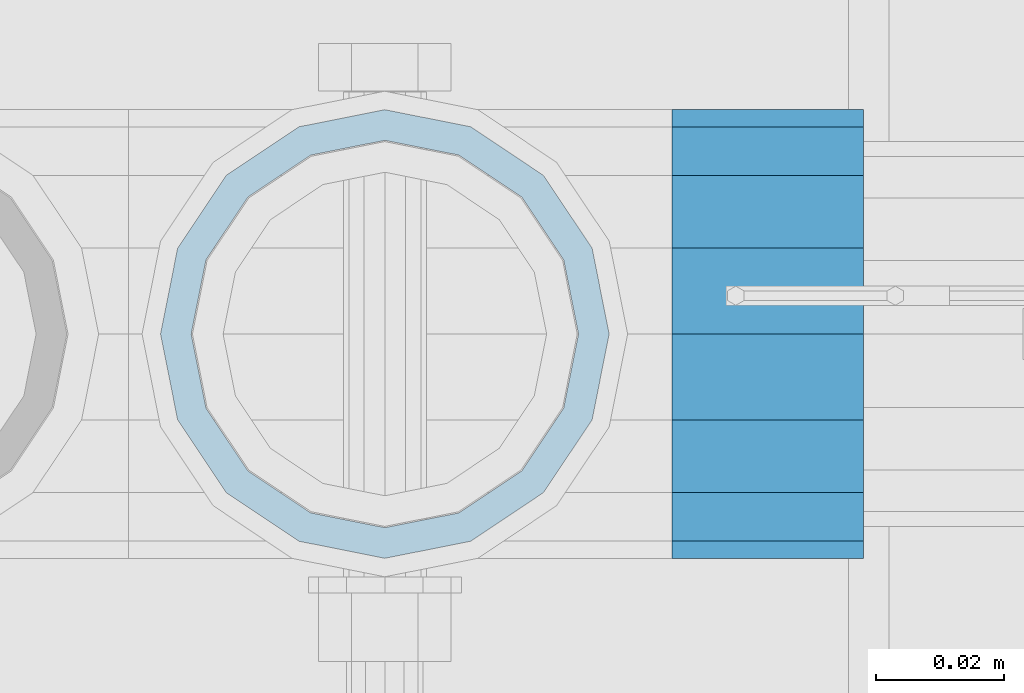
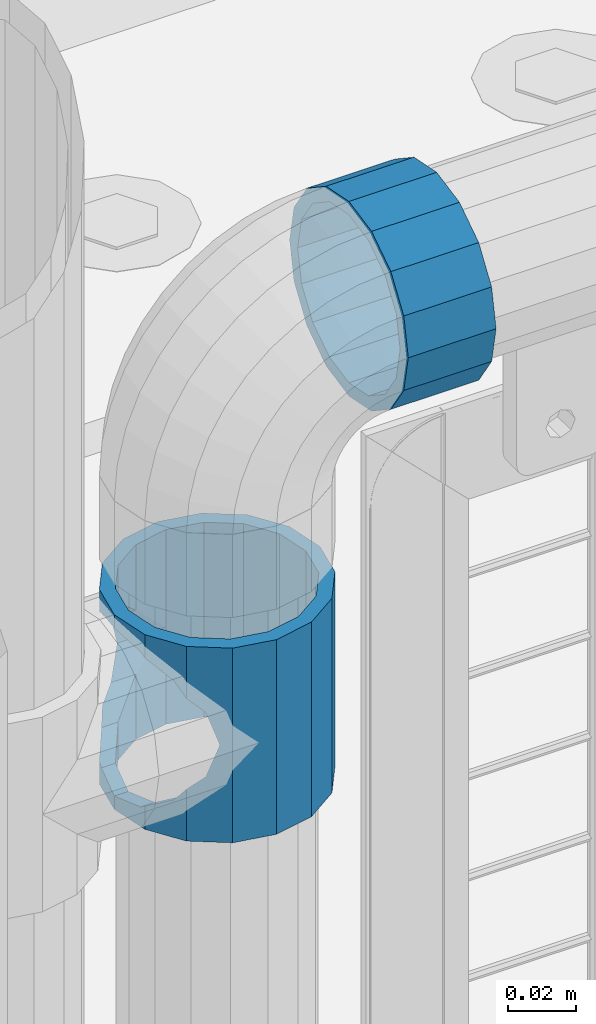
# One storey, part 146 of 240: 2 beams.
"""IFC2X3 building model written with IfcOpenShell, lengths in millimetres."""

from ifc_helpers import new_model, si_unit, frame, origin_with_axes, place, context, subcontext, project, spatial, faceted_brep, material, type_object, element, save


model = new_model("IFC2X3")

# Units and contexts
model_context = context("Model", 3, precision=1e-05, world=origin_with_axes())
body_context = subcontext(model_context, "Body", "Model", "MODEL_VIEW")
ifc_project = project(units=[si_unit("LENGTHUNIT", "METRE", prefix="MILLI"), si_unit("AREAUNIT", "SQUARE_METRE"), si_unit("VOLUMEUNIT", "CUBIC_METRE"), si_unit("MASSUNIT", "GRAM", prefix="KILO"), si_unit("TIMEUNIT", "SECOND"), si_unit("PLANEANGLEUNIT", "RADIAN"), si_unit("SOLIDANGLEUNIT", "STERADIAN"), si_unit("THERMODYNAMICTEMPERATUREUNIT", "DEGREE_CELSIUS"), si_unit("LUMINOUSINTENSITYUNIT", "LUMEN")], contexts=[model_context])

# Site, building, storey
site_placement = place(None, origin_with_axes())
site = spatial("IfcSite", under=ifc_project, at=site_placement, CompositionType="ELEMENT")
building_placement = place(site_placement, origin_with_axes())
building = spatial("IfcBuilding", under=site, at=building_placement, Name="Standard", CompositionType="ELEMENT")
storey_placement = place(building_placement, origin_with_axes())
storey = spatial("IfcBuildingStorey", under=building, at=storey_placement, Name="Undefined", CompositionType="ELEMENT", Elevation=0.0)

# Beams
ifc_material = material(Name="Misc_Undefined")
beam_type = type_object("IfcBeamType", PredefinedType="NOTDEFINED")
beam_1_placement = place(storey_placement, frame((43071.0, 34664.5, 883.820000000001), z_axis=(1.0, 0.0, 0.0), x_axis=(0.0, 0.0, -1.0)))
element("IfcBeam", 1, at=beam_1_placement, inside=storey, type_object=beam_type, material=ifc_material, context=body_context, shape_type="Brep", body=[
    faceted_brep([(46.7644421722801, 28.0397438117143, -11.6144421722784), (46.7644421722801, 28.0397438117143, -20.0882031229849), (51.5310424079941, 24.8548033587067, -24.8548033587067), (56.6106908090114, 21.4606908090136, -27.1226768591077), (56.6106908090114, 21.4606908090136, -21.4606908090136), (61.9623795176703, 13.4513226476338, -32.4743655677739), (63.1897438117172, 11.6144421722784, -32.8397438117172), (63.1897438117172, 11.6144421722784, -28.0397438117143), (65.4999999999997, 0.0, -35.1500000000015), (65.4999999999997, 0.0, -30.3499999999985), (63.1897438117172, -11.6144421722784, -32.8397438117245), (63.1897438117172, -11.6144421722784, -28.0397438117143), (61.9623795176703, -13.4513226476338, -32.4743655677739), (56.6106908090114, -21.4606908090136, -27.1226768591223), (56.6106908090114, -21.4606908090136, -21.4606908090136), (51.5310424080006, -24.8548033587067, -24.8548033587067), (46.7644421722801, -28.0397438117143, -20.0882031229994), (46.7644421722801, -28.0397438117143, -11.6144421722784), (35.1499999999996, -30.3499999999985, -16.6306603983758), (35.1500000000015, -30.35, 0.0), (23.5355578277191, -28.0397438117143, -20.0882031229994), (23.5355578277191, -28.0397438117143, -11.6144421722784), (18.7689575919987, -24.8548033587067, -24.8548033587067), (13.6893091909879, -21.4606908090136, -27.1226768591223), (13.6893091909879, -21.4606908090136, -21.4606908090136), (8.33762048232455, -13.4513226476338, -32.4743655677739), (7.11025618828211, -11.6144421722784, -32.8397438117245), (7.11025618828211, -11.6144421722784, -28.0397438117143), (4.79999999999961, 0.0, -35.1500000000015), (4.79999999999961, 0.0, -30.3499999999985), (7.11025618828211, 11.6144421722784, -32.8397438117172), (7.11025618828211, 11.6144421722784, -28.0397438117143), (8.33762048232893, 13.4513226476338, -32.4743655677739), (13.6893091909879, 21.4606908090136, -27.1226768591077), (13.6893091909879, 21.4606908090136, -21.4606908090136), (18.7689575919921, 24.8548033587067, -24.8548033587067), (23.5355578277192, 28.0397438117143, -20.0882031229849), (23.5355578277192, 28.0397438117143, -11.6144421722784), (35.1499999999996, 30.3499999999985, -16.6306603983685), (35.1500000000015, 30.35, 0.0), (0.0, 32.4743655677739, -13.4513226476338), (0.0, 35.1500000000015, 0.0), (70.2999999999993, 35.1500000000015, 0.0), (70.2999999999993, 32.4743655677739, -13.4513226476338), (0.0, 32.4743655677739, 13.4513226476338), (70.2999999999993, 32.4743655677739, 13.4513226476338), (0.0, 24.8548033587067, 24.8548033587067), (70.2999999999993, 24.8548033587067, 24.8548033587067), (0.0, 13.4513226476338, 32.4743655677739), (70.2999999999993, 13.4513226476338, 32.4743655677739), (0.0, 0.0, 35.1500000000015), (70.2999999999993, 0.0, 35.1500000000015), (0.0, -13.4513226476338, 32.4743655677739), (70.2999999999993, -13.4513226476338, 32.4743655677739), (0.0, -24.8548033587067, 24.8548033587067), (70.2999999999993, -24.8548033587067, 24.8548033587067), (0.0, -32.4743655677739, 13.4513226476338), (70.2999999999993, -32.4743655677739, 13.4513226476338), (0.0, -35.1500000000015, 0.0), (70.2999999999993, -35.1500000000015, 0.0), (70.2999999999993, -30.3499999999985, 0.0), (70.2999999999993, -28.0397438117143, -11.6144421722784), (70.2999999999993, -21.4606908090136, -21.4606908090136), (70.2999999999993, -11.6144421722784, -28.0397438117143), (70.2999999999993, 0.0, -30.3499999999985), (70.2999999999993, 11.6144421722784, -28.0397438117143), (70.2999999999993, 21.4606908090136, -21.4606908090136), (70.2999999999993, 28.0397438117143, -11.6144421722784), (0.0, -28.0397438117143, -11.6144421722784), (0.0, -30.3499999999985, 0.0), (0.0, -21.4606908090136, -21.4606908090136), (0.0, -11.6144421722784, -28.0397438117143), (0.0, 0.0, -30.3499999999985), (0.0, 11.6144421722784, -28.0397438117143), (0.0, 21.4606908090136, -21.4606908090136), (0.0, 28.0397438117143, -11.6144421722784), (0.0, 30.3499999999985, 0.0), (70.2999999999993, 30.3499999999985, 0.0), (0.0, 28.0397438117143, 11.6144421722784), (70.2999999999993, 28.0397438117143, 11.6144421722784), (0.0, 21.4606908090136, 21.4606908090136), (70.2999999999993, 21.4606908090136, 21.4606908090136), (0.0, 11.6144421722784, 28.0397438117143), (70.2999999999993, 11.6144421722784, 28.0397438117143), (0.0, 0.0, 30.3499999999985), (70.2999999999993, 0.0, 30.3499999999985), (0.0, -11.6144421722784, 28.0397438117143), (70.2999999999993, -11.6144421722784, 28.0397438117143), (0.0, -21.4606908090136, 21.4606908090136), (70.2999999999993, -21.4606908090136, 21.4606908090136), (0.0, -28.0397438117143, 11.6144421722784), (70.2999999999993, -28.0397438117143, 11.6144421722784), (70.2999999999993, -24.8548033587067, -24.8548033587067), (70.2999999999993, -13.4513226476338, -32.4743655677739), (70.2999999999993, 0.0, -35.1500000000015), (70.2999999999993, 13.4513226476338, -32.4743655677739), (70.2999999999993, 24.8548033587067, -24.8548033587067), (70.2999999999993, -32.4743655677739, -13.4513226476338), (0.0, -32.4743655677739, -13.4513226476338), (0.0, 24.8548033587067, -24.8548033587067), (0.0, 13.4513226476338, -32.4743655677739), (0.0, 0.0, -35.1500000000015), (0.0, -13.4513226476338, -32.4743655677739), (0.0, -24.8548033587067, -24.8548033587067)], [[[0, 1, 2, 3, 4]], [[4, 3, 5, 6, 7]], [[7, 6, 8, 9]], [[9, 8, 10, 11]], [[11, 10, 12, 13, 14]], [[14, 13, 15, 16, 17]], [[17, 16, 18, 19]], [[19, 18, 20, 21]], [[21, 20, 22, 23, 24]], [[24, 23, 25, 26, 27]], [[27, 26, 28, 29]], [[29, 28, 30, 31]], [[31, 30, 32, 33, 34]], [[34, 33, 35, 36, 37]], [[37, 36, 38, 39]], [[39, 38, 1, 0]], [[40, 41, 42, 43]], [[41, 44, 45, 42]], [[44, 46, 47, 45]], [[46, 48, 49, 47]], [[48, 50, 51, 49]], [[50, 52, 53, 51]], [[52, 54, 55, 53]], [[54, 56, 57, 55]], [[56, 58, 59, 57]], [[60, 61, 17, 19]], [[61, 62, 14, 17]], [[62, 63, 11, 14]], [[63, 64, 9, 11]], [[64, 65, 7, 9]], [[65, 66, 4, 7]], [[66, 67, 0, 4]], [[68, 69, 19, 21]], [[70, 68, 21, 24]], [[71, 70, 24, 27]], [[72, 71, 27, 29]], [[73, 72, 29, 31]], [[74, 73, 31, 34]], [[75, 74, 34, 37]], [[76, 75, 37, 39]], [[67, 77, 39, 0]], [[78, 76, 39, 77, 79]], [[80, 78, 79, 81]], [[82, 80, 81, 83]], [[84, 82, 83, 85]], [[86, 84, 85, 87]], [[88, 86, 87, 89]], [[90, 88, 89, 91]], [[19, 69, 90, 91, 60]], [[92, 93, 94, 95, 96, 43, 42, 45, 47, 49, 51, 53, 55, 57, 59, 97], [89, 87, 85, 83, 81, 79, 77, 67, 66, 65, 64, 63, 62, 61, 60, 91]], [[58, 98, 97, 59]], [[56, 54, 52, 50, 48, 46, 44, 41, 40, 99, 100, 101, 102, 103, 98, 58], [68, 70, 71, 72, 73, 74, 75, 76, 78, 80, 82, 84, 86, 88, 90, 69]], [[32, 100, 99, 35, 33]], [[28, 101, 100, 32, 30]], [[102, 101, 28, 26, 25]], [[103, 102, 25, 23, 22]], [[15, 92, 97, 98, 103, 22, 20, 18, 16]], [[12, 93, 92, 15, 13]], [[8, 94, 93, 12, 10]], [[95, 94, 8, 6, 5]], [[96, 95, 5, 3, 2]], [[35, 99, 40, 43, 96, 2, 1, 38, 36]]]),
])
beam_2_placement = place(storey_placement, frame((43116.0, 34664.5, 969.849999999999), z_axis=(0.0, 0.0, 1.0), x_axis=(1.0, 0.0, 0.0)))
element("IfcBeam", 2, at=beam_2_placement, inside=storey, type_object=beam_type, material=ifc_material, context=body_context, shape_type="Brep", body=[
    faceted_brep([(0.0, -30.3499999999985, 0.0), (0.0, -28.0397438117143, 11.6144421722784), (30.0, -28.0397438117143, 11.6144421722805), (30.0, -30.3499999999985, 0.0), (0.0, -21.4606908090136, 21.4606908090136), (30.0, -21.4606908090136, 21.4606908090117), (0.0, -11.6144421722784, 28.0397438117143), (30.0, -11.6144421722784, 28.0397438117176), (0.0, 0.0, 30.3499999999985), (30.0, 0.0, 30.35), (0.0, 11.6144421722784, 28.0397438117143), (30.0, 11.6144421722784, 28.0397438117176), (0.0, 21.4606908090136, 21.4606908090136), (30.0, 21.4606908090136, 21.4606908090117), (0.0, 28.0397438117143, 11.6144421722784), (30.0, 28.0397438117143, 11.6144421722805), (0.0, 30.3499999999985, 0.0), (30.0, 30.3499999999985, 0.0), (0.0, 28.0397438117143, -11.6144421722784), (30.0, 28.0397438117143, -11.6144421722805), (0.0, 21.4606908090136, -21.4606908090136), (30.0, 21.4606908090136, -21.4606908090117), (0.0, 11.6144421722784, -28.0397438117143), (30.0, 11.6144421722784, -28.0397438117176), (0.0, 0.0, -30.3499999999985), (30.0, 0.0, -30.35), (0.0, -11.6144421722784, -28.0397438117143), (30.0, -11.6144421722784, -28.0397438117176), (0.0, -21.4606908090136, -21.4606908090136), (30.0, -21.4606908090136, -21.4606908090117), (0.0, -28.0397438117143, -11.6144421722784), (30.0, -28.0397438117143, -11.6144421722805), (0.0, -35.1500000000015, 0.0), (0.0, -32.4743655677739, -13.4513226476338), (30.0, -32.4743655677739, -13.4513226476329), (30.0, -35.1500000000015, 0.0), (0.0, -24.8548033587067, -24.8548033587067), (30.0, -24.8548033587067, -24.8548033587072), (0.0, -13.4513226476338, -32.4743655677739), (30.0, -13.4513226476338, -32.4743655677718), (0.0, 0.0, -35.1500000000015), (30.0, 0.0, -35.15), (0.0, 13.4513226476338, -32.4743655677739), (30.0, 13.4513226476338, -32.4743655677718), (0.0, 24.8548033587067, -24.8548033587067), (30.0, 24.8548033587067, -24.8548033587072), (0.0, 32.4743655677739, -13.4513226476338), (30.0, 32.4743655677739, -13.4513226476329), (0.0, 35.1500000000015, 0.0), (30.0, 35.1500000000015, 0.0), (0.0, 32.4743655677739, 13.4513226476338), (30.0, 32.4743655677739, 13.4513226476329), (0.0, 24.8548033587067, 24.8548033587067), (30.0, 24.8548033587067, 24.8548033587072), (0.0, 13.4513226476338, 32.4743655677739), (30.0, 13.4513226476338, 32.4743655677718), (0.0, 0.0, 35.1500000000015), (30.0, 0.0, 35.15), (0.0, -13.4513226476338, 32.4743655677739), (30.0, -13.4513226476338, 32.4743655677718), (0.0, -24.8548033587067, 24.8548033587067), (30.0, -24.8548033587067, 24.8548033587072), (0.0, -32.4743655677739, 13.4513226476338), (30.0, -32.4743655677739, 13.4513226476329)], [[[0, 1, 2, 3]], [[1, 4, 5, 2]], [[4, 6, 7, 5]], [[6, 8, 9, 7]], [[8, 10, 11, 9]], [[10, 12, 13, 11]], [[12, 14, 15, 13]], [[14, 16, 17, 15]], [[16, 18, 19, 17]], [[18, 20, 21, 19]], [[20, 22, 23, 21]], [[22, 24, 25, 23]], [[24, 26, 27, 25]], [[26, 28, 29, 27]], [[28, 30, 31, 29]], [[30, 0, 3, 31]], [[32, 33, 34, 35]], [[33, 36, 37, 34]], [[36, 38, 39, 37]], [[38, 40, 41, 39]], [[40, 42, 43, 41]], [[42, 44, 45, 43]], [[44, 46, 47, 45]], [[46, 48, 49, 47]], [[48, 50, 51, 49]], [[50, 52, 53, 51]], [[52, 54, 55, 53]], [[54, 56, 57, 55]], [[56, 58, 59, 57]], [[58, 60, 61, 59]], [[60, 62, 63, 61]], [[62, 32, 35, 63]], [[37, 39, 41, 43, 45, 47, 49, 51, 53, 55, 57, 59, 61, 63, 35, 34], [5, 7, 9, 11, 13, 15, 17, 19, 21, 23, 25, 27, 29, 31, 3, 2]], [[62, 60, 58, 56, 54, 52, 50, 48, 46, 44, 42, 40, 38, 36, 33, 32], [30, 28, 26, 24, 22, 20, 18, 16, 14, 12, 10, 8, 6, 4, 1, 0]]]),
])

save(model, "model.ifc")
